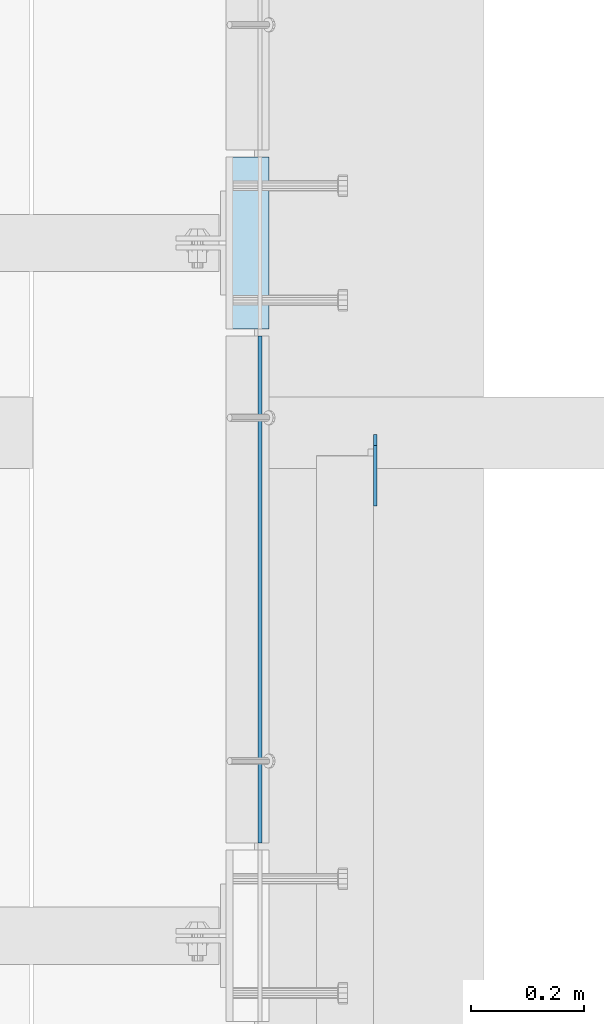
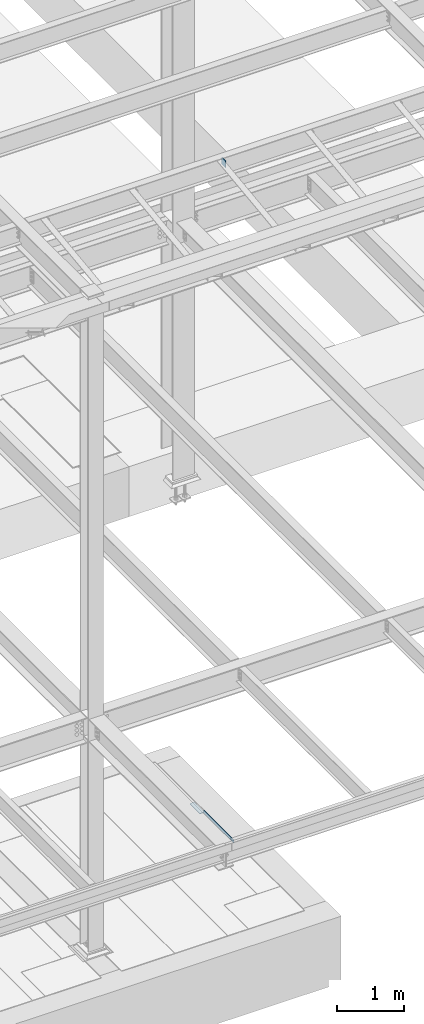
# One storey, part 3171 of 3843: 3 plates, 3 elements without a shape of their own.
"""IFC2X3 building model written with IfcOpenShell, lengths in millimetres."""

from ifc_helpers import new_model, si_unit, frame, origin_with_axes, place, context, subcontext, project, spatial, faceted_brep, material, type_object, element, aggregate, save


model = new_model("IFC2X3")

# Units and contexts
model_context = context("Model", 3, precision=1e-05, world=origin_with_axes())
body_context = subcontext(model_context, "Body", "Model", "MODEL_VIEW")
ifc_project = project(units=[si_unit("LENGTHUNIT", "METRE", prefix="MILLI"), si_unit("AREAUNIT", "SQUARE_METRE"), si_unit("VOLUMEUNIT", "CUBIC_METRE"), si_unit("MASSUNIT", "GRAM", prefix="KILO"), si_unit("TIMEUNIT", "SECOND"), si_unit("PLANEANGLEUNIT", "RADIAN"), si_unit("SOLIDANGLEUNIT", "STERADIAN"), si_unit("THERMODYNAMICTEMPERATUREUNIT", "DEGREE_CELSIUS"), si_unit("LUMINOUSINTENSITYUNIT", "LUMEN")], contexts=[model_context])

# Site, building, storey
site_placement = place(None, origin_with_axes())
site = spatial("IfcSite", under=ifc_project, at=site_placement, CompositionType="ELEMENT")
building_placement = place(site_placement, origin_with_axes())
building = spatial("IfcBuilding", under=site, at=building_placement, Name="Undefined", CompositionType="ELEMENT")
storey_placement = place(building_placement, origin_with_axes())
storey = spatial("IfcBuildingStorey", under=building, at=storey_placement, Name="Undefined", CompositionType="ELEMENT", Elevation=0.0)

# Assembly, plate
assembly_1_placement = place(storey_placement, origin_with_axes())
assembly_1 = element("IfcElementAssembly", 1, at=assembly_1_placement, inside=storey, Name="EMBED PLATE", AssemblyPlace="NOTDEFINED", PredefinedType="RIGID_FRAME")
ifc_material_1 = material(Name="STEEL/A36")
plate_type_1 = type_object("IfcPlateType", PredefinedType="NOTDEFINED")
plate_1_placement = place(assembly_1_placement, frame((65843.1499969482, 17306.925, 30426.025), z_axis=(0.0, 1.0, 0.0), x_axis=(1.0, 0.0, 0.0)))
plate_1 = element("IfcPlate", 2, at=plate_1_placement, type_object=plate_type_1, material=ifc_material_1, Name="PLATE", context=body_context, shape_type="Brep", body=[
    faceted_brep([(0.0, -3.17499999999927, 0.0), (0.0, -3.17499999999927, 304.800000000003), (0.0, 3.17499999999927, 304.800000000003), (0.0, 3.17499999999927, 0.0), (76.1999999999971, -3.17499999999927, 304.799999999996), (76.1999999999971, 3.17499999999927, 304.799999999996), (76.1999999999971, -3.17499999999927, 0.0), (76.1999999999971, 3.17499999999927, 0.0)], [[[0, 1, 2, 3]], [[1, 4, 5, 2]], [[4, 6, 7, 5]], [[6, 0, 3, 7]], [[5, 7, 3, 2]], [[6, 4, 1, 0]]]),
])
aggregate(assembly_1, [plate_1])

assembly_2_placement = place(storey_placement, origin_with_axes())
assembly_2 = element("IfcElementAssembly", 3, at=assembly_2_placement, inside=storey, Name="ANGLE", AssemblyPlace="NOTDEFINED", PredefinedType="RIGID_FRAME")
plate_type_2 = type_object("IfcPlateType", PredefinedType="NOTDEFINED")
plate_2_placement = place(assembly_2_placement, frame((65903.4750008939, 16394.1125001617, 30429.2000030518), z_axis=(0.0, 0.999999999997942, -2.02899998962774e-06), x_axis=(0.0, 2.02899999567308e-06, 0.999999999997942)))
plate_2 = element("IfcPlate", 4, at=plate_2_placement, type_object=plate_type_2, material=ifc_material_1, Name="PLATE", context=body_context, shape_type="Brep", body=[
    faceted_brep([(0.0, -3.17499999999927, 0.0), (0.00181156927283155, -3.1749999984022, 900.111999510274), (0.00181156927283155, 3.17500000159635, 900.11199951026), (0.0, 3.17499999999927, 0.0), (50.8018112192949, -3.1749999984022, 900.111999510213), (50.8018112192949, 3.17500000159635, 900.111999510198), (50.7999954217848, -3.17499999999563, -7.27595761418343e-12), (50.7999954217848, 3.17500000001019, -1.09139364212751e-11)], [[[0, 1, 2, 3]], [[1, 4, 5, 2]], [[4, 6, 7, 5]], [[6, 0, 3, 7]], [[5, 7, 3, 2]], [[6, 4, 1, 0]]]),
])
aggregate(assembly_2, [plate_2])

assembly_3_placement = place(storey_placement, origin_with_axes())
assembly_3 = element("IfcElementAssembly", 5, at=assembly_3_placement, inside=storey, Name="BEAM", AssemblyPlace="NOTDEFINED", PredefinedType="RIGID_FRAME")
ifc_material_2 = material(Name="STEEL/A572-50")
plate_type_3 = type_object("IfcPlateType", PredefinedType="NOTDEFINED")
plate_3_placement = place(assembly_3_placement, frame((66108.2625, 17118.965, 42330.6875), z_axis=(0.0, 0.0, 1.0), x_axis=(0.0, -1.0, 0.0)))
plate_3 = element("IfcPlate", 6, at=plate_3_placement, type_object=plate_type_3, material=ifc_material_2, Name="PLATE", context=body_context, shape_type="Brep", body=[
    faceted_brep([(0.0, -3.17499999999927, 0.0), (0.0, -3.17500000000291, 107.950000000004), (0.0, 3.17500000000291, 107.950000000004), (0.0, 3.17499999999927, 0.0), (19.0500000000029, -3.17500000000291, 127.0), (19.0500000000029, 3.17500000000291, 127.0), (127.0, -3.17500000000291, 127.0), (127.0, 3.17500000000291, 127.0), (127.0, -3.17500000000291, 0.0), (127.0, 3.17500000000291, 0.0)], [[[0, 1, 2, 3]], [[1, 4, 5, 2]], [[4, 6, 7, 5]], [[6, 8, 9, 7]], [[8, 0, 3, 9]], [[5, 7, 9, 3, 2]], [[8, 6, 4, 1, 0]]]),
])
aggregate(assembly_3, [plate_3])

save(model, "model.ifc")
